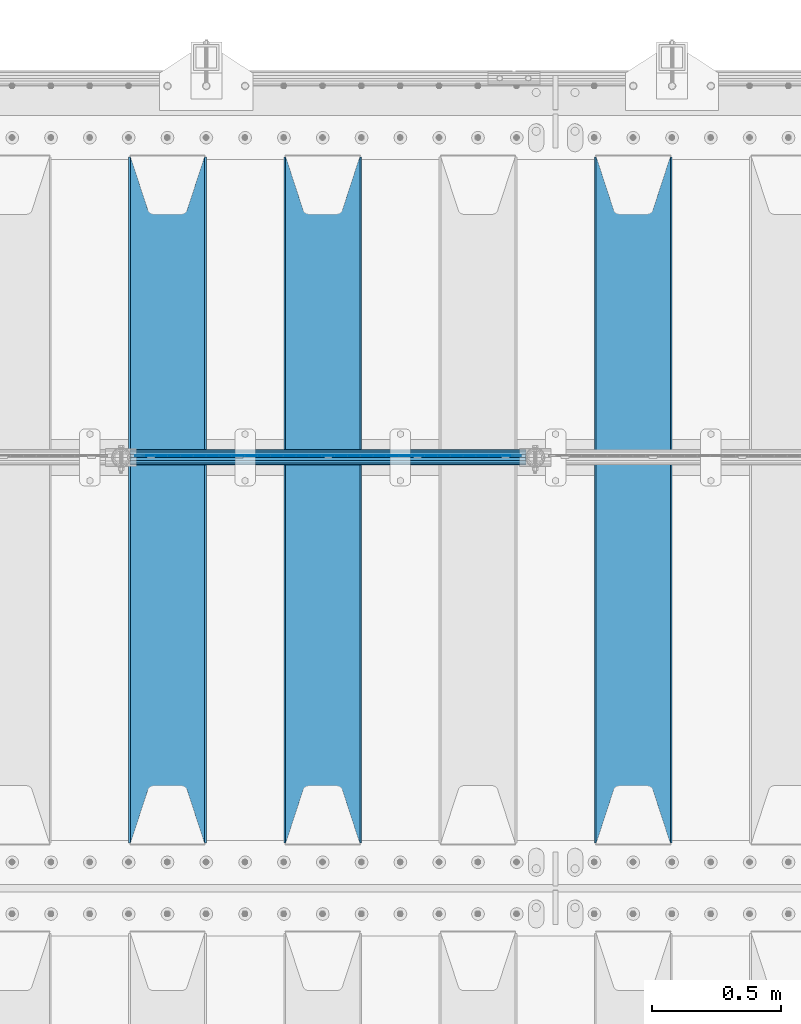
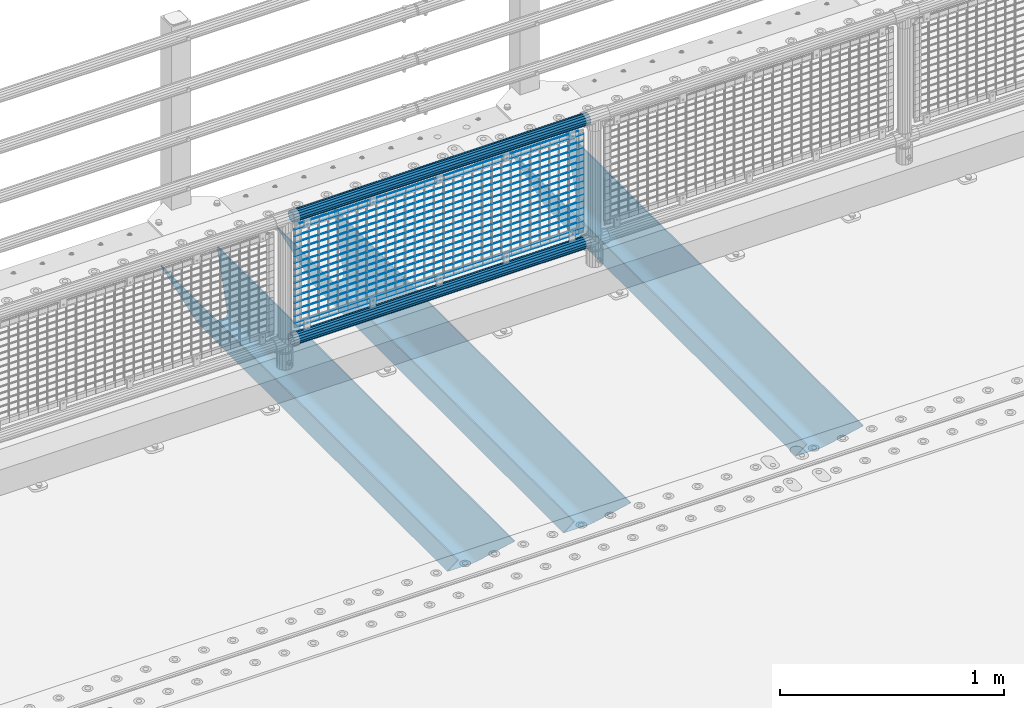
# One storey, part 118 of 257: 22 beams.
"""IFC2X3 building model written with IfcOpenShell, lengths in millimetres."""

from ifc_helpers import new_model, si_unit, frame, origin_with_axes, place, context, subcontext, project, spatial, faceted_brep, material, type_object, element, save


model = new_model("IFC2X3")

# Units and contexts
model_context = context("Model", 3, precision=1e-05, world=origin_with_axes())
body_context = subcontext(model_context, "Body", "Model", "MODEL_VIEW")
ifc_project = project(units=[si_unit("LENGTHUNIT", "METRE", prefix="MILLI"), si_unit("AREAUNIT", "SQUARE_METRE"), si_unit("VOLUMEUNIT", "CUBIC_METRE"), si_unit("MASSUNIT", "GRAM", prefix="KILO"), si_unit("TIMEUNIT", "SECOND"), si_unit("PLANEANGLEUNIT", "RADIAN"), si_unit("SOLIDANGLEUNIT", "STERADIAN"), si_unit("THERMODYNAMICTEMPERATUREUNIT", "DEGREE_CELSIUS"), si_unit("LUMINOUSINTENSITYUNIT", "LUMEN")], contexts=[model_context])

# Site, building, storey
site_placement = place(None, origin_with_axes())
site = spatial("IfcSite", under=ifc_project, at=site_placement, CompositionType="ELEMENT")
building_placement = place(site_placement, origin_with_axes())
building = spatial("IfcBuilding", under=site, at=building_placement, Name="Standard", CompositionType="ELEMENT")
storey_placement = place(building_placement, origin_with_axes())
storey = spatial("IfcBuildingStorey", under=building, at=storey_placement, Name="Undefined", CompositionType="ELEMENT", Elevation=0.0)

# Beams
ifc_material_1 = material(Name="STEEL/S355N")
beam_type_1 = type_object("IfcBeamType", PredefinedType="NOTDEFINED")
beam_1_placement = place(storey_placement, frame((48250.0, 9175.0, -115.0), z_axis=(0.0, 0.0, 1.0), x_axis=(0.0, 1.0, 0.0)))
element("IfcBeam", 1, at=beam_1_placement, inside=storey, type_object=beam_type_1, material=ifc_material_1, context=body_context, shape_type="Brep", body=[
    faceted_brep([(0.0, 150.0, 115.0), (0.0, 143.690000000002, 115.0), (2650.00000000297, 143.690000000002, 115.0), (2650.00000000297, 150.0, 115.0), (2650.00000000297, 142.059565218406, 110.0000000031), (2650.00000000297, 148.369565218403, 110.0000000031), (2441.90079219208, -80.1103600731149, -98.0992078077845), (2437.7588105432, -77.5672621345584, -102.241189456673), (2434.06523489746, -74.4080125315522, -105.934765102404), (2430.91086095089, -70.7102721255724, -109.089139048974), (2428.37322971128, -66.5649389910031, -111.626770288588), (2426.51472138055, -62.0739139532889, -113.485278619323), (2425.38102192091, -57.3475956567636, -114.618978078955), (2424.99999999987, -52.5021667386536, -115.0), (2424.99999999987, 52.5021667386536, -115.0), (2425.38102192091, 57.3475956567636, -114.618978078955), (2426.51472138055, 62.0739139532889, -113.485278619323), (2428.37322971128, 66.5649389910031, -111.626770288588), (2430.91086095089, 70.7102721255724, -109.089139048974), (2434.06523489746, 74.4080125315522, -105.934765102404), (2437.7588105432, 77.5672621345584, -102.241189456673), (2441.90079219208, 80.1103600731149, -98.0992078077846), (2446.38936140511, 81.9747917625791, -93.6106385947584), (2448.24948500409, 76.2713538057287, -91.7505149957729), (2444.62967112262, 74.76777986261, -95.3703288772456), (2441.28936334126, 72.7168944282894, -98.710636658607), (2438.31067330438, 70.1691124903809, -101.689326695487), (2435.76682334747, 67.1870637758839, -104.233176652398), (2433.72034654133, 63.8440531834931, -106.279653458539), (2432.22154950041, 60.2222587982324, -107.778450499454), (2431.30727574265, 56.4107117849126, -108.692724257221), (2430.99999999987, 52.5031078186876, -109.0), (2430.99999999987, -52.5031078186876, -109.0), (2431.30727574265, -56.4107117849126, -108.692724257221), (2432.22154950041, -60.2222587982324, -107.778450499454), (2433.72034654133, -63.8440531834931, -106.279653458539), (2435.76682334747, -67.1870637758839, -104.233176652398), (2438.31067330438, -70.1691124903809, -101.689326695487), (2441.28936334126, -72.7168944282894, -98.7106366586071), (2444.62967112262, -74.76777986261, -95.3703288772457), (2448.24948500409, -76.2713538057287, -91.7505149957729), (2650.00000000297, -142.059565218406, 110.0000000031), (2650.00000000297, -148.369565218403, 110.0000000031), (2446.38936140511, -81.9747917625791, -93.6106385947584), (2650.00000000297, -143.690000000002, 115.0), (2650.00000000297, -150.0, 115.0), (0.0, -143.690000000002, 115.0), (0.0, -150.0, 115.0), (0.0, -148.369565218258, 110.000000002662), (203.61063859742, -81.9747917625791, -93.6106385947584), (208.099207810447, -80.1103600731149, -98.0992078077845), (212.241189459335, -77.5672621345584, -102.241189456673), (215.934765105066, -74.4080125315522, -105.934765102404), (219.089139051636, -70.7102721255724, -109.089139048974), (221.626770291251, -66.5649389910031, -111.626770288588), (223.485278621985, -62.0739139532889, -113.485278619323), (224.618978081617, -57.3475956567636, -114.618978078955), (225.000000002662, -52.5021667386536, -115.0), (225.000000002662, 52.5021667386536, -115.0), (224.618978081617, 57.3475956567636, -114.618978078955), (223.485278621985, 62.0739139532889, -113.485278619323), (221.626770291251, 66.5649389910031, -111.626770288588), (219.089139051636, 70.7102721255724, -109.089139048974), (215.934765105066, 74.4080125315522, -105.934765102404), (212.241189459335, 77.5672621345584, -102.241189456673), (208.099207810447, 80.1103600731149, -98.0992078077846), (203.61063859742, 81.9747917625791, -93.6106385947584), (0.0, 148.369565218258, 110.000000002662), (0.0, 142.05956521826, 110.000000002662), (201.750514998435, 76.2713538057287, -91.7505149957729), (205.370328879908, 74.76777986261, -95.3703288772456), (208.710636661269, 72.7168944282894, -98.710636658607), (211.689326698149, 70.1691124903809, -101.689326695487), (214.233176655061, 67.1870637758839, -104.233176652398), (216.279653461201, 63.8440531834931, -106.279653458539), (217.778450502116, 60.2222587982324, -107.778450499454), (218.692724259884, 56.4107117849126, -108.692724257221), (219.000000002662, 52.5031078186876, -109.0), (219.000000002662, -52.5031078186876, -109.0), (218.692724259884, -56.4107117849126, -108.692724257221), (217.778450502116, -60.2222587982324, -107.778450499454), (216.279653461201, -63.8440531834931, -106.279653458539), (214.233176655061, -67.1870637758839, -104.233176652398), (211.689326698149, -70.1691124903809, -101.689326695487), (208.710636661269, -72.7168944282894, -98.7106366586071), (205.370328879908, -74.76777986261, -95.3703288772457), (201.750514998435, -76.2713538057287, -91.7505149957729), (0.0, -142.05956521826, 110.000000002662)], [[[0, 1, 2, 3]], [[3, 2, 4, 5]], [[6, 7, 8, 9, 10, 11, 12, 13, 14, 15, 16, 17, 18, 19, 20, 21, 22, 5, 4, 23, 24, 25, 26, 27, 28, 29, 30, 31, 32, 33, 34, 35, 36, 37, 38, 39, 40, 41, 42, 43]], [[44, 45, 42, 41]], [[46, 47, 45, 44]], [[43, 42, 45, 47, 48, 49]], [[6, 43, 49, 50]], [[7, 6, 50, 51]], [[8, 7, 51, 52]], [[9, 8, 52, 53]], [[10, 9, 53, 54]], [[11, 10, 54, 55]], [[12, 11, 55, 56]], [[13, 12, 56, 57]], [[14, 13, 57, 58]], [[15, 14, 58, 59]], [[16, 15, 59, 60]], [[17, 16, 60, 61]], [[18, 17, 61, 62]], [[19, 18, 62, 63]], [[20, 19, 63, 64]], [[21, 20, 64, 65]], [[22, 21, 65, 66]], [[0, 3, 5, 22, 66, 67]], [[1, 0, 67, 68]], [[23, 4, 2, 1, 68, 69]], [[24, 23, 69, 70]], [[25, 24, 70, 71]], [[26, 25, 71, 72]], [[27, 26, 72, 73]], [[28, 27, 73, 74]], [[29, 28, 74, 75]], [[30, 29, 75, 76]], [[31, 30, 76, 77]], [[32, 31, 77, 78]], [[33, 32, 78, 79]], [[34, 33, 79, 80]], [[35, 34, 80, 81]], [[36, 35, 81, 82]], [[37, 36, 82, 83]], [[38, 37, 83, 84]], [[39, 38, 84, 85]], [[40, 39, 85, 86]], [[46, 44, 41, 40, 86, 87]], [[47, 46, 87, 48]], [[86, 85, 84, 83, 82, 81, 80, 79, 78, 77, 76, 75, 74, 73, 72, 71, 70, 69, 68, 67, 66, 65, 64, 63, 62, 61, 60, 59, 58, 57, 56, 55, 54, 53, 52, 51, 50, 49, 48, 87]]]),
])
beam_2_placement = place(storey_placement, frame((47050.0, 9175.0, -115.0), z_axis=(0.0, 0.0, 1.0), x_axis=(0.0, 1.0, 0.0)))
element("IfcBeam", 2, at=beam_2_placement, inside=storey, type_object=beam_type_1, material=ifc_material_1, context=body_context, shape_type="Brep", body=[
    faceted_brep([(0.0, 150.0, 115.0), (0.0, 143.690000000002, 115.0), (2650.00000000297, 143.690000000002, 115.0), (2650.00000000297, 150.0, 115.0), (2650.00000000297, 142.059565218406, 110.0000000031), (2650.00000000297, 148.369565218403, 110.0000000031), (2441.90079219208, -80.1103600731149, -98.0992078077845), (2437.7588105432, -77.5672621345584, -102.241189456673), (2434.06523489746, -74.4080125315522, -105.934765102404), (2430.91086095089, -70.7102721255724, -109.089139048974), (2428.37322971128, -66.5649389910031, -111.626770288588), (2426.51472138055, -62.0739139532889, -113.485278619323), (2425.38102192091, -57.3475956567636, -114.618978078955), (2424.99999999987, -52.5021667386536, -115.0), (2424.99999999987, 52.5021667386536, -115.0), (2425.38102192091, 57.3475956567636, -114.618978078955), (2426.51472138055, 62.0739139532889, -113.485278619323), (2428.37322971128, 66.5649389910031, -111.626770288588), (2430.91086095089, 70.7102721255724, -109.089139048974), (2434.06523489746, 74.4080125315522, -105.934765102404), (2437.7588105432, 77.5672621345584, -102.241189456673), (2441.90079219208, 80.1103600731149, -98.0992078077846), (2446.38936140511, 81.9747917625791, -93.6106385947584), (2448.24948500409, 76.2713538057287, -91.7505149957729), (2444.62967112262, 74.76777986261, -95.3703288772456), (2441.28936334126, 72.7168944282894, -98.710636658607), (2438.31067330438, 70.1691124903809, -101.689326695487), (2435.76682334747, 67.1870637758839, -104.233176652398), (2433.72034654133, 63.8440531834931, -106.279653458539), (2432.22154950041, 60.2222587982324, -107.778450499454), (2431.30727574265, 56.4107117849126, -108.692724257221), (2430.99999999987, 52.5031078186876, -109.0), (2430.99999999987, -52.5031078186876, -109.0), (2431.30727574265, -56.4107117849126, -108.692724257221), (2432.22154950041, -60.2222587982324, -107.778450499454), (2433.72034654133, -63.8440531834931, -106.279653458539), (2435.76682334747, -67.1870637758839, -104.233176652398), (2438.31067330438, -70.1691124903809, -101.689326695487), (2441.28936334126, -72.7168944282894, -98.7106366586071), (2444.62967112262, -74.76777986261, -95.3703288772457), (2448.24948500409, -76.2713538057287, -91.7505149957729), (2650.00000000297, -142.059565218406, 110.0000000031), (2650.00000000297, -148.369565218403, 110.0000000031), (2446.38936140511, -81.9747917625791, -93.6106385947584), (2650.00000000297, -143.690000000002, 115.0), (2650.00000000297, -150.0, 115.0), (0.0, -143.690000000002, 115.0), (0.0, -150.0, 115.0), (0.0, -148.369565218258, 110.000000002662), (203.61063859742, -81.9747917625791, -93.6106385947584), (208.099207810447, -80.1103600731149, -98.0992078077845), (212.241189459335, -77.5672621345584, -102.241189456673), (215.934765105066, -74.4080125315522, -105.934765102404), (219.089139051636, -70.7102721255724, -109.089139048974), (221.626770291251, -66.5649389910031, -111.626770288588), (223.485278621985, -62.0739139532889, -113.485278619323), (224.618978081617, -57.3475956567636, -114.618978078955), (225.000000002662, -52.5021667386536, -115.0), (225.000000002662, 52.5021667386536, -115.0), (224.618978081617, 57.3475956567636, -114.618978078955), (223.485278621985, 62.0739139532889, -113.485278619323), (221.626770291251, 66.5649389910031, -111.626770288588), (219.089139051636, 70.7102721255724, -109.089139048974), (215.934765105066, 74.4080125315522, -105.934765102404), (212.241189459335, 77.5672621345584, -102.241189456673), (208.099207810447, 80.1103600731149, -98.0992078077846), (203.61063859742, 81.9747917625791, -93.6106385947584), (0.0, 148.369565218258, 110.000000002662), (0.0, 142.05956521826, 110.000000002662), (201.750514998435, 76.2713538057287, -91.7505149957729), (205.370328879908, 74.76777986261, -95.3703288772456), (208.710636661269, 72.7168944282894, -98.710636658607), (211.689326698149, 70.1691124903809, -101.689326695487), (214.233176655061, 67.1870637758839, -104.233176652398), (216.279653461201, 63.8440531834931, -106.279653458539), (217.778450502116, 60.2222587982324, -107.778450499454), (218.692724259884, 56.4107117849126, -108.692724257221), (219.000000002662, 52.5031078186876, -109.0), (219.000000002662, -52.5031078186876, -109.0), (218.692724259884, -56.4107117849126, -108.692724257221), (217.778450502116, -60.2222587982324, -107.778450499454), (216.279653461201, -63.8440531834931, -106.279653458539), (214.233176655061, -67.1870637758839, -104.233176652398), (211.689326698149, -70.1691124903809, -101.689326695487), (208.710636661269, -72.7168944282894, -98.7106366586071), (205.370328879908, -74.76777986261, -95.3703288772457), (201.750514998435, -76.2713538057287, -91.7505149957729), (0.0, -142.05956521826, 110.000000002662)], [[[0, 1, 2, 3]], [[3, 2, 4, 5]], [[6, 7, 8, 9, 10, 11, 12, 13, 14, 15, 16, 17, 18, 19, 20, 21, 22, 5, 4, 23, 24, 25, 26, 27, 28, 29, 30, 31, 32, 33, 34, 35, 36, 37, 38, 39, 40, 41, 42, 43]], [[44, 45, 42, 41]], [[46, 47, 45, 44]], [[43, 42, 45, 47, 48, 49]], [[6, 43, 49, 50]], [[7, 6, 50, 51]], [[8, 7, 51, 52]], [[9, 8, 52, 53]], [[10, 9, 53, 54]], [[11, 10, 54, 55]], [[12, 11, 55, 56]], [[13, 12, 56, 57]], [[14, 13, 57, 58]], [[15, 14, 58, 59]], [[16, 15, 59, 60]], [[17, 16, 60, 61]], [[18, 17, 61, 62]], [[19, 18, 62, 63]], [[20, 19, 63, 64]], [[21, 20, 64, 65]], [[22, 21, 65, 66]], [[0, 3, 5, 22, 66, 67]], [[1, 0, 67, 68]], [[23, 4, 2, 1, 68, 69]], [[24, 23, 69, 70]], [[25, 24, 70, 71]], [[26, 25, 71, 72]], [[27, 26, 72, 73]], [[28, 27, 73, 74]], [[29, 28, 74, 75]], [[30, 29, 75, 76]], [[31, 30, 76, 77]], [[32, 31, 77, 78]], [[33, 32, 78, 79]], [[34, 33, 79, 80]], [[35, 34, 80, 81]], [[36, 35, 81, 82]], [[37, 36, 82, 83]], [[38, 37, 83, 84]], [[39, 38, 84, 85]], [[40, 39, 85, 86]], [[46, 44, 41, 40, 86, 87]], [[47, 46, 87, 48]], [[86, 85, 84, 83, 82, 81, 80, 79, 78, 77, 76, 75, 74, 73, 72, 71, 70, 69, 68, 67, 66, 65, 64, 63, 62, 61, 60, 59, 58, 57, 56, 55, 54, 53, 52, 51, 50, 49, 48, 87]]]),
])
beam_3_placement = place(storey_placement, frame((46450.0, 9175.0, -115.0), z_axis=(0.0, 0.0, 1.0), x_axis=(0.0, 1.0, 0.0)))
element("IfcBeam", 3, at=beam_3_placement, inside=storey, type_object=beam_type_1, material=ifc_material_1, context=body_context, shape_type="Brep", body=[
    faceted_brep([(0.0, 150.0, 115.0), (0.0, 143.690000000002, 115.0), (2650.00000000297, 143.690000000002, 115.0), (2650.00000000297, 150.0, 115.0), (2650.00000000297, 142.059565218406, 110.0000000031), (2650.00000000297, 148.369565218403, 110.0000000031), (2441.90079219208, -80.1103600731149, -98.0992078077845), (2437.7588105432, -77.5672621345584, -102.241189456673), (2434.06523489746, -74.4080125315522, -105.934765102404), (2430.91086095089, -70.7102721255724, -109.089139048974), (2428.37322971128, -66.5649389910031, -111.626770288588), (2426.51472138055, -62.0739139532889, -113.485278619323), (2425.38102192091, -57.3475956567636, -114.618978078955), (2424.99999999987, -52.5021667386536, -115.0), (2424.99999999987, 52.5021667386536, -115.0), (2425.38102192091, 57.3475956567636, -114.618978078955), (2426.51472138055, 62.0739139532889, -113.485278619323), (2428.37322971128, 66.5649389910031, -111.626770288588), (2430.91086095089, 70.7102721255724, -109.089139048974), (2434.06523489746, 74.4080125315522, -105.934765102404), (2437.7588105432, 77.5672621345584, -102.241189456673), (2441.90079219208, 80.1103600731149, -98.0992078077846), (2446.38936140511, 81.9747917625791, -93.6106385947584), (2448.24948500409, 76.2713538057287, -91.7505149957729), (2444.62967112262, 74.76777986261, -95.3703288772456), (2441.28936334126, 72.7168944282894, -98.710636658607), (2438.31067330438, 70.1691124903809, -101.689326695487), (2435.76682334747, 67.1870637758839, -104.233176652398), (2433.72034654133, 63.8440531834931, -106.279653458539), (2432.22154950041, 60.2222587982324, -107.778450499454), (2431.30727574265, 56.4107117849126, -108.692724257221), (2430.99999999987, 52.5031078186876, -109.0), (2430.99999999987, -52.5031078186876, -109.0), (2431.30727574265, -56.4107117849126, -108.692724257221), (2432.22154950041, -60.2222587982324, -107.778450499454), (2433.72034654133, -63.8440531834931, -106.279653458539), (2435.76682334747, -67.1870637758839, -104.233176652398), (2438.31067330438, -70.1691124903809, -101.689326695487), (2441.28936334126, -72.7168944282894, -98.7106366586071), (2444.62967112262, -74.76777986261, -95.3703288772457), (2448.24948500409, -76.2713538057287, -91.7505149957729), (2650.00000000297, -142.059565218406, 110.0000000031), (2650.00000000297, -148.369565218403, 110.0000000031), (2446.38936140511, -81.9747917625791, -93.6106385947584), (2650.00000000297, -143.690000000002, 115.0), (2650.00000000297, -150.0, 115.0), (0.0, -143.690000000002, 115.0), (0.0, -150.0, 115.0), (0.0, -148.369565218258, 110.000000002662), (203.61063859742, -81.9747917625791, -93.6106385947584), (208.099207810447, -80.1103600731149, -98.0992078077845), (212.241189459335, -77.5672621345584, -102.241189456673), (215.934765105066, -74.4080125315522, -105.934765102404), (219.089139051636, -70.7102721255724, -109.089139048974), (221.626770291251, -66.5649389910031, -111.626770288588), (223.485278621985, -62.0739139532889, -113.485278619323), (224.618978081617, -57.3475956567636, -114.618978078955), (225.000000002662, -52.5021667386536, -115.0), (225.000000002662, 52.5021667386536, -115.0), (224.618978081617, 57.3475956567636, -114.618978078955), (223.485278621985, 62.0739139532889, -113.485278619323), (221.626770291251, 66.5649389910031, -111.626770288588), (219.089139051636, 70.7102721255724, -109.089139048974), (215.934765105066, 74.4080125315522, -105.934765102404), (212.241189459335, 77.5672621345584, -102.241189456673), (208.099207810447, 80.1103600731149, -98.0992078077846), (203.61063859742, 81.9747917625791, -93.6106385947584), (0.0, 148.369565218258, 110.000000002662), (0.0, 142.05956521826, 110.000000002662), (201.750514998435, 76.2713538057287, -91.7505149957729), (205.370328879908, 74.76777986261, -95.3703288772456), (208.710636661269, 72.7168944282894, -98.710636658607), (211.689326698149, 70.1691124903809, -101.689326695487), (214.233176655061, 67.1870637758839, -104.233176652398), (216.279653461201, 63.8440531834931, -106.279653458539), (217.778450502116, 60.2222587982324, -107.778450499454), (218.692724259884, 56.4107117849126, -108.692724257221), (219.000000002662, 52.5031078186876, -109.0), (219.000000002662, -52.5031078186876, -109.0), (218.692724259884, -56.4107117849126, -108.692724257221), (217.778450502116, -60.2222587982324, -107.778450499454), (216.279653461201, -63.8440531834931, -106.279653458539), (214.233176655061, -67.1870637758839, -104.233176652398), (211.689326698149, -70.1691124903809, -101.689326695487), (208.710636661269, -72.7168944282894, -98.7106366586071), (205.370328879908, -74.76777986261, -95.3703288772457), (201.750514998435, -76.2713538057287, -91.7505149957729), (0.0, -142.05956521826, 110.000000002662)], [[[0, 1, 2, 3]], [[3, 2, 4, 5]], [[6, 7, 8, 9, 10, 11, 12, 13, 14, 15, 16, 17, 18, 19, 20, 21, 22, 5, 4, 23, 24, 25, 26, 27, 28, 29, 30, 31, 32, 33, 34, 35, 36, 37, 38, 39, 40, 41, 42, 43]], [[44, 45, 42, 41]], [[46, 47, 45, 44]], [[43, 42, 45, 47, 48, 49]], [[6, 43, 49, 50]], [[7, 6, 50, 51]], [[8, 7, 51, 52]], [[9, 8, 52, 53]], [[10, 9, 53, 54]], [[11, 10, 54, 55]], [[12, 11, 55, 56]], [[13, 12, 56, 57]], [[14, 13, 57, 58]], [[15, 14, 58, 59]], [[16, 15, 59, 60]], [[17, 16, 60, 61]], [[18, 17, 61, 62]], [[19, 18, 62, 63]], [[20, 19, 63, 64]], [[21, 20, 64, 65]], [[22, 21, 65, 66]], [[0, 3, 5, 22, 66, 67]], [[1, 0, 67, 68]], [[23, 4, 2, 1, 68, 69]], [[24, 23, 69, 70]], [[25, 24, 70, 71]], [[26, 25, 71, 72]], [[27, 26, 72, 73]], [[28, 27, 73, 74]], [[29, 28, 74, 75]], [[30, 29, 75, 76]], [[31, 30, 76, 77]], [[32, 31, 77, 78]], [[33, 32, 78, 79]], [[34, 33, 79, 80]], [[35, 34, 80, 81]], [[36, 35, 81, 82]], [[37, 36, 82, 83]], [[38, 37, 83, 84]], [[39, 38, 84, 85]], [[40, 39, 85, 86]], [[46, 44, 41, 40, 86, 87]], [[47, 46, 87, 48]], [[86, 85, 84, 83, 82, 81, 80, 79, 78, 77, 76, 75, 74, 73, 72, 71, 70, 69, 68, 67, 66, 65, 64, 63, 62, 61, 60, 59, 58, 57, 56, 55, 54, 53, 52, 51, 50, 49, 48, 87]]]),
])
ifc_material_2 = material(Name="Misc_Undefined")
beam_type_2 = type_object("IfcBeamType", Name="D3", PredefinedType="NOTDEFINED")
for number, where, z_axis, x_axis in (
    (4, (46326.0, 10670.5, 851.597), (0.0, 0.0, 1.0), (1.0, 0.0, 0.0)),
    (5, (46326.0, 10670.5, 669.452), (0.0, 0.0, 1.0), (1.0, 0.0, 0.0)),
    (6, (46326.0, 10670.5, 523.736), (0.0, 0.0, 1.0), (1.0, 0.0, 0.0)),
    (7, (46326.0, 10670.5, 487.307), (0.0, 0.0, 1.0), (1.0, 0.0, 0.0)),
    (8, (46326.0, 10670.5, 705.881), (0.0, 0.0, 1.0), (1.0, 0.0, 0.0)),
    (9, (46326.0, 10670.5, 596.594000000001), (0.0, 0.0, 1.0), (1.0, 0.0, 0.0)),
    (10, (46326.0, 10670.5, 450.878), (0.0, 0.0, 1.0), (1.0, 0.0, 0.0)),
    (11, (46326.0, 10670.5, 815.168), (0.0, 0.0, 1.0), (1.0, 0.0, 0.0)),
    (12, (46326.0, 10670.5, 888.026), (0.0, 0.0, 1.0), (1.0, 0.0, 0.0)),
    (13, (46326.0, 10670.5, 778.739), (0.0, 0.0, 1.0), (1.0, 0.0, 0.0)),
    (14, (46326.0, 10670.5, 742.31), (0.0, 0.0, 1.0), (1.0, 0.0, 0.0)),
    (15, (46326.0, 10670.5, 633.023), (0.0, 0.0, 1.0), (1.0, 0.0, 0.0)),
    (16, (46326.0, 10670.5, 560.165), (0.0, 0.0, 1.0), (1.0, 0.0, 0.0)),
    (17, (46326.0, 10670.5, 414.449), (0.0, 0.0, 1.0), (1.0, 0.0, 0.0)),
):
    element("IfcBeam", number, at=place(storey_placement, frame(where, z_axis=z_axis, x_axis=x_axis)), inside=storey, type_object=beam_type_2, material=ifc_material_2, ObjectType="D3", context=body_context, shape_type="Brep", body=[
        faceted_brep([(0.0, -1.5, -5.6843418860808e-14), (0.0, -0.750000000001819, -1.29903810567669), (1490.0, -0.75, -1.29903810567669), (1490.0, -1.5, 0.0), (7.27595761418343e-12, 0.749999999998181, -1.29903810567669), (1490.0, 0.75, -1.29903810567669), (0.0, 1.5, -5.6843418860808e-14), (1490.0, 1.5, 0.0), (7.27595761418343e-12, 0.749999999998181, 1.29903810567669), (1490.0, 0.75, 1.29903810567669), (0.0, -0.750000000001819, 1.29903810567669), (1490.0, -0.75, 1.29903810567669)], [[[0, 1, 2, 3]], [[1, 4, 5, 2]], [[4, 6, 7, 5]], [[6, 8, 9, 7]], [[8, 10, 11, 9]], [[10, 0, 3, 11]], [[5, 7, 9, 11, 3, 2]], [[10, 8, 6, 4, 1, 0]]]),
    ])
beam_4_placement = place(storey_placement, frame((46351.0, 10670.5, 353.02), z_axis=(0.0, 0.0, 1.0), x_axis=(1.0, 0.0, 0.0)))
element("IfcBeam", 18, at=beam_4_placement, inside=storey, type_object=beam_type_2, material=ifc_material_2, ObjectType="D3", context=body_context, shape_type="Brep", body=[
    faceted_brep([(0.0, -1.5, -5.6843418860808e-14), (0.0, -0.750000000001819, -1.29903810567669), (1440.0, -0.75, -1.29903810567669), (1440.0, -1.5, 0.0), (7.27595761418343e-12, 0.749999999998181, -1.29903810567669), (1440.0, 0.75, -1.29903810567663), (0.0, 1.5, -5.6843418860808e-14), (1440.0, 1.5, 0.0), (7.27595761418343e-12, 0.749999999998181, 1.29903810567669), (1440.0, 0.75, 1.29903810567669), (0.0, -0.750000000001819, 1.29903810567669), (1440.0, -0.75, 1.29903810567669)], [[[0, 1, 2, 3]], [[1, 4, 5, 2]], [[4, 6, 7, 5]], [[6, 8, 9, 7]], [[8, 10, 11, 9]], [[10, 0, 3, 11]], [[5, 7, 9, 11, 3, 2]], [[10, 8, 6, 4, 1, 0]]]),
])
beam_5_placement = place(storey_placement, frame((46326.0, 10670.5, 378.02), z_axis=(0.0, 0.0, 1.0), x_axis=(1.0, 0.0, 0.0)))
element("IfcBeam", 19, at=beam_5_placement, inside=storey, type_object=beam_type_2, material=ifc_material_2, ObjectType="D3", context=body_context, shape_type="Brep", body=[
    faceted_brep([(0.0, -1.5, -5.6843418860808e-14), (0.0, -0.750000000001819, -1.29903810567669), (1490.0, -0.75, -1.29903810567669), (1490.0, -1.5, 0.0), (7.27595761418343e-12, 0.749999999998181, -1.29903810567669), (1490.0, 0.75, -1.29903810567669), (0.0, 1.5, -5.6843418860808e-14), (1490.0, 1.5, 0.0), (7.27595761418343e-12, 0.749999999998181, 1.29903810567669), (1490.0, 0.75, 1.29903810567669), (0.0, -0.750000000001819, 1.29903810567669), (1490.0, -0.75, 1.29903810567669)], [[[0, 1, 2, 3]], [[1, 4, 5, 2]], [[4, 6, 7, 5]], [[6, 8, 9, 7]], [[8, 10, 11, 9]], [[10, 0, 3, 11]], [[5, 7, 9, 11, 3, 2]], [[10, 8, 6, 4, 1, 0]]]),
])
beam_6_placement = place(storey_placement, frame((46351.0, 10670.5, 913.02), z_axis=(0.0, 0.0, 1.0), x_axis=(1.0, 0.0, 0.0)))
element("IfcBeam", 20, at=beam_6_placement, inside=storey, type_object=beam_type_2, material=ifc_material_2, ObjectType="D3", context=body_context, shape_type="Brep", body=[
    faceted_brep([(0.0, -1.5, -5.6843418860808e-14), (0.0, -0.750000000001819, -1.29903810567669), (1440.0, -0.75, -1.29903810567669), (1440.0, -1.5, 0.0), (7.27595761418343e-12, 0.749999999998181, -1.29903810567669), (1440.0, 0.75, -1.29903810567663), (0.0, 1.5, -5.6843418860808e-14), (1440.0, 1.5, 0.0), (7.27595761418343e-12, 0.749999999998181, 1.29903810567669), (1440.0, 0.75, 1.29903810567669), (0.0, -0.750000000001819, 1.29903810567669), (1440.0, -0.75, 1.29903810567669)], [[[0, 1, 2, 3]], [[1, 4, 5, 2]], [[4, 6, 7, 5]], [[6, 8, 9, 7]], [[8, 10, 11, 9]], [[10, 0, 3, 11]], [[5, 7, 9, 11, 3, 2]], [[10, 8, 6, 4, 1, 0]]]),
])
ifc_material_3 = material()
beam_type_3 = type_object("IfcBeamType", PredefinedType="NOTDEFINED")
beam_7_placement = place(storey_placement, frame((46305.85, 10664.5, 298.170000000002), z_axis=(0.0, 0.0, 1.0), x_axis=(1.0, 0.0, 0.0)))
element("IfcBeam", 21, at=beam_7_placement, inside=storey, type_object=beam_type_3, material=ifc_material_3, context=body_context, shape_type="Brep", body=[
    faceted_brep([(0.0, -25.3500000000004, 0.0), (0.0, -23.4203461491616, 9.70102501045767), (1530.0, -23.4203461491616, 9.70102501045506), (1530.0, -25.3500000000004, 0.0), (0.0, -17.9251569030785, 17.9251569030821), (1530.0, -17.9251569030785, 17.925156903079), (0.0, -9.70102501045585, 23.4203461491634), (1530.0, -9.70102501045585, 23.4203461491611), (0.0, 0.0, 25.3499999999985), (1530.0, 0.0, 25.35), (0.0, 9.70102501045585, 23.4203461491634), (1530.0, 9.70102501045585, 23.4203461491611), (0.0, 17.9251569030785, 17.9251569030821), (1530.0, 17.9251569030785, 17.925156903079), (0.0, 23.4203461491616, 9.70102501045767), (1530.0, 23.4203461491616, 9.701025010455), (0.0, 25.3500000000004, 0.0), (1530.0, 25.3500000000004, 0.0), (0.0, 23.4203461491616, -9.70102501045767), (1530.0, 23.4203461491616, -9.70102501045506), (0.0, 17.9251569030785, -17.9251569030821), (1530.0, 17.9251569030785, -17.925156903079), (0.0, 9.70102501045585, -23.4203461491634), (1530.0, 9.70102501045585, -23.4203461491611), (0.0, 0.0, -25.3499999999985), (1530.0, 0.0, -25.35), (0.0, -9.70102501045585, -23.4203461491634), (1530.0, -9.70102501045585, -23.4203461491611), (0.0, -17.9251569030785, -17.9251569030821), (1530.0, -17.9251569030785, -17.925156903079), (0.0, -23.4203461491616, -9.70102501045767), (1530.0, -23.4203461491616, -9.701025010455), (0.0, -30.1499999999996, 0.0), (0.0, -27.8549679052157, -11.5379054858058), (1530.0, -27.8549679052157, -11.5379054858075), (1530.0, -30.1499999999996, 0.0), (0.0, -21.3192694527752, -21.3192694527752), (1530.0, -21.3192694527752, -21.3192694527744), (0.0, -11.5379054858076, -27.8549679052157), (1530.0, -11.5379054858076, -27.8549679052153), (0.0, 0.0, -30.1500000000015), (1530.0, 0.0, -30.15), (0.0, 11.5379054858076, -27.8549679052157), (1530.0, 11.5379054858076, -27.8549679052153), (0.0, 21.3192694527752, -21.3192694527752), (1530.0, 21.3192694527752, -21.3192694527744), (0.0, 27.8549679052157, -11.5379054858058), (1530.0, 27.8549679052157, -11.5379054858075), (0.0, 30.1499999999996, 0.0), (1530.0, 30.1499999999996, 0.0), (0.0, 27.8549679052157, 11.5379054858058), (1530.0, 27.8549679052157, 11.5379054858075), (0.0, 21.3192694527752, 21.3192694527752), (1530.0, 21.3192694527752, 21.3192694527744), (0.0, 11.5379054858076, 27.8549679052157), (1530.0, 11.5379054858076, 27.8549679052153), (0.0, 0.0, 30.1500000000015), (1530.0, 0.0, 30.15), (0.0, -11.5379054858076, 27.8549679052157), (1530.0, -11.5379054858076, 27.8549679052153), (0.0, -21.3192694527752, 21.3192694527752), (1530.0, -21.3192694527752, 21.3192694527744), (0.0, -27.8549679052157, 11.5379054858058), (1530.0, -27.8549679052157, 11.5379054858075)], [[[0, 1, 2, 3]], [[1, 4, 5, 2]], [[4, 6, 7, 5]], [[6, 8, 9, 7]], [[8, 10, 11, 9]], [[10, 12, 13, 11]], [[12, 14, 15, 13]], [[14, 16, 17, 15]], [[16, 18, 19, 17]], [[18, 20, 21, 19]], [[20, 22, 23, 21]], [[22, 24, 25, 23]], [[24, 26, 27, 25]], [[26, 28, 29, 27]], [[28, 30, 31, 29]], [[30, 0, 3, 31]], [[32, 33, 34, 35]], [[33, 36, 37, 34]], [[36, 38, 39, 37]], [[38, 40, 41, 39]], [[40, 42, 43, 41]], [[42, 44, 45, 43]], [[44, 46, 47, 45]], [[46, 48, 49, 47]], [[48, 50, 51, 49]], [[50, 52, 53, 51]], [[52, 54, 55, 53]], [[54, 56, 57, 55]], [[56, 58, 59, 57]], [[58, 60, 61, 59]], [[60, 62, 63, 61]], [[62, 32, 35, 63]], [[37, 39, 41, 43, 45, 47, 49, 51, 53, 55, 57, 59, 61, 63, 35, 34], [5, 7, 9, 11, 13, 15, 17, 19, 21, 23, 25, 27, 29, 31, 3, 2]], [[62, 60, 58, 56, 54, 52, 50, 48, 46, 44, 42, 40, 38, 36, 33, 32], [30, 28, 26, 24, 22, 20, 18, 16, 14, 12, 10, 8, 6, 4, 1, 0]]]),
])
beam_8_placement = place(storey_placement, frame((46305.85, 10664.5, 969.85), z_axis=(0.0, 0.0, 1.0), x_axis=(1.0, 0.0, 0.0)))
element("IfcBeam", 22, at=beam_8_placement, inside=storey, type_object=beam_type_3, material=ifc_material_3, context=body_context, shape_type="Brep", body=[
    faceted_brep([(0.0, -25.3500000000004, 0.0), (0.0, -23.4203461491616, 9.70102501045767), (1530.0, -23.4203461491616, 9.70102501045506), (1530.0, -25.3500000000004, 0.0), (0.0, -17.9251569030785, 17.9251569030821), (1530.0, -17.9251569030785, 17.925156903079), (0.0, -9.70102501045585, 23.4203461491634), (1530.0, -9.70102501045585, 23.4203461491611), (0.0, 0.0, 25.3499999999985), (1530.0, 0.0, 25.35), (0.0, 9.70102501045585, 23.4203461491634), (1530.0, 9.70102501045585, 23.4203461491611), (0.0, 17.9251569030785, 17.9251569030821), (1530.0, 17.9251569030785, 17.925156903079), (0.0, 23.4203461491616, 9.70102501045767), (1530.0, 23.4203461491616, 9.701025010455), (0.0, 25.3500000000004, 0.0), (1530.0, 25.3500000000004, 0.0), (0.0, 23.4203461491616, -9.70102501045767), (1530.0, 23.4203461491616, -9.70102501045506), (0.0, 17.9251569030785, -17.9251569030821), (1530.0, 17.9251569030785, -17.925156903079), (0.0, 9.70102501045585, -23.4203461491634), (1530.0, 9.70102501045585, -23.4203461491611), (0.0, 0.0, -25.3499999999985), (1530.0, 0.0, -25.35), (0.0, -9.70102501045585, -23.4203461491634), (1530.0, -9.70102501045585, -23.4203461491611), (0.0, -17.9251569030785, -17.9251569030821), (1530.0, -17.9251569030785, -17.925156903079), (0.0, -23.4203461491616, -9.70102501045767), (1530.0, -23.4203461491616, -9.701025010455), (0.0, -30.1499999999996, 0.0), (0.0, -27.8549679052157, -11.5379054858058), (1530.0, -27.8549679052157, -11.5379054858075), (1530.0, -30.1499999999996, 0.0), (0.0, -21.3192694527752, -21.3192694527752), (1530.0, -21.3192694527752, -21.3192694527744), (0.0, -11.5379054858076, -27.8549679052157), (1530.0, -11.5379054858076, -27.8549679052153), (0.0, 0.0, -30.1500000000015), (1530.0, 0.0, -30.15), (0.0, 11.5379054858076, -27.8549679052157), (1530.0, 11.5379054858076, -27.8549679052153), (0.0, 21.3192694527752, -21.3192694527752), (1530.0, 21.3192694527752, -21.3192694527744), (0.0, 27.8549679052157, -11.5379054858058), (1530.0, 27.8549679052157, -11.5379054858075), (0.0, 30.1499999999996, 0.0), (1530.0, 30.1499999999996, 0.0), (0.0, 27.8549679052157, 11.5379054858058), (1530.0, 27.8549679052157, 11.5379054858075), (0.0, 21.3192694527752, 21.3192694527752), (1530.0, 21.3192694527752, 21.3192694527744), (0.0, 11.5379054858076, 27.8549679052157), (1530.0, 11.5379054858076, 27.8549679052153), (0.0, 0.0, 30.1500000000015), (1530.0, 0.0, 30.15), (0.0, -11.5379054858076, 27.8549679052157), (1530.0, -11.5379054858076, 27.8549679052153), (0.0, -21.3192694527752, 21.3192694527752), (1530.0, -21.3192694527752, 21.3192694527744), (0.0, -27.8549679052157, 11.5379054858058), (1530.0, -27.8549679052157, 11.5379054858075)], [[[0, 1, 2, 3]], [[1, 4, 5, 2]], [[4, 6, 7, 5]], [[6, 8, 9, 7]], [[8, 10, 11, 9]], [[10, 12, 13, 11]], [[12, 14, 15, 13]], [[14, 16, 17, 15]], [[16, 18, 19, 17]], [[18, 20, 21, 19]], [[20, 22, 23, 21]], [[22, 24, 25, 23]], [[24, 26, 27, 25]], [[26, 28, 29, 27]], [[28, 30, 31, 29]], [[30, 0, 3, 31]], [[32, 33, 34, 35]], [[33, 36, 37, 34]], [[36, 38, 39, 37]], [[38, 40, 41, 39]], [[40, 42, 43, 41]], [[42, 44, 45, 43]], [[44, 46, 47, 45]], [[46, 48, 49, 47]], [[48, 50, 51, 49]], [[50, 52, 53, 51]], [[52, 54, 55, 53]], [[54, 56, 57, 55]], [[56, 58, 59, 57]], [[58, 60, 61, 59]], [[60, 62, 63, 61]], [[62, 32, 35, 63]], [[37, 39, 41, 43, 45, 47, 49, 51, 53, 55, 57, 59, 61, 63, 35, 34], [5, 7, 9, 11, 13, 15, 17, 19, 21, 23, 25, 27, 29, 31, 3, 2]], [[62, 60, 58, 56, 54, 52, 50, 48, 46, 44, 42, 40, 38, 36, 33, 32], [30, 28, 26, 24, 22, 20, 18, 16, 14, 12, 10, 8, 6, 4, 1, 0]]]),
])

save(model, "model.ifc")
